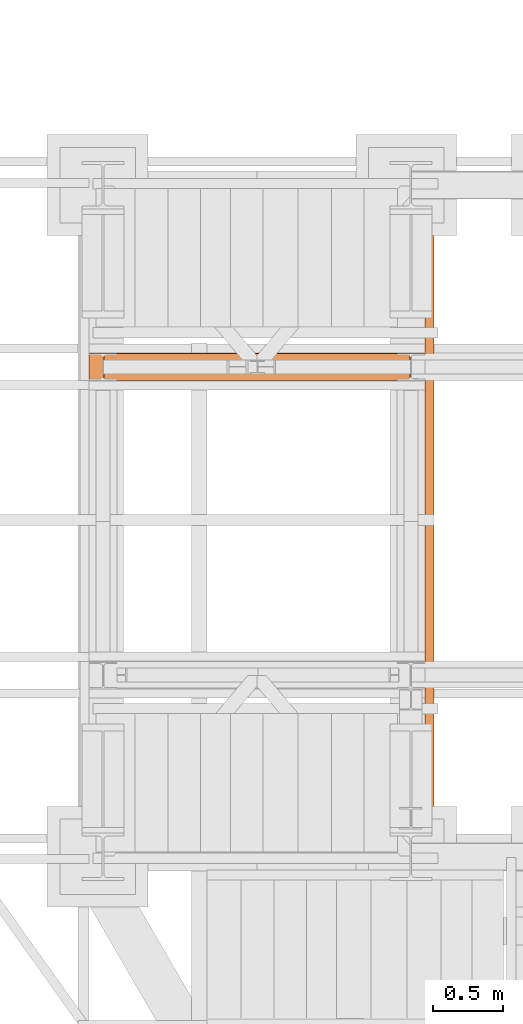
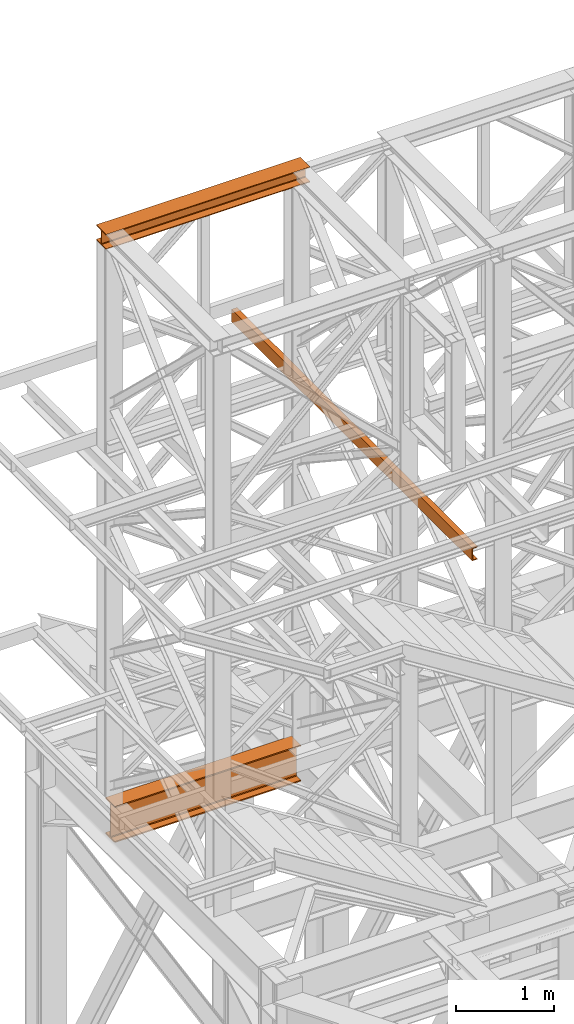
# One storey, part 101 of 208: 3 proxies.
"""IFC2X3 building model written with IfcOpenShell, lengths in millimetres."""

from ifc_helpers import new_model, entity, si_unit, converted_unit, frame, origin, origin_with_axes, place, context, subcontext, project, spatial, faceted_brep, element, save


model = new_model("IFC2X3")

# Units and contexts
model_context = context("Model", 3, precision=1e-05, world=origin())
plan_context = context("Plan", 3, precision=1e-05, world=origin())
body_context = subcontext(model_context, "Body", "Model", "MODEL_VIEW")
ifc_project = project(units=[si_unit("LENGTHUNIT", "METRE", prefix="MILLI"), converted_unit("PLANEANGLEUNIT", "DEGREE", entity("IfcPlaneAngleMeasure", 0.0174532925199433), si_unit("PLANEANGLEUNIT", "RADIAN"), dimensions=[0, 0, 0, 0, 0, 0, 0]), si_unit("AREAUNIT", "SQUARE_METRE"), si_unit("VOLUMEUNIT", "CUBIC_METRE")], contexts=[model_context, plan_context])

# Building, storey
building_placement = place(None, origin())
building = spatial("IfcBuilding", under=ifc_project, at=building_placement, CompositionType="COMPLEX")
storey_placement = place(building_placement, origin_with_axes())
storey = spatial("IfcBuildingStorey", under=building, at=storey_placement, Name="Geschoss", CompositionType="ELEMENT")

# Proxies
proxy_1_placement = place(storey_placement, frame((-3300.745031419179, -13857.57439657637, 4834.989987483023), z_axis=(0.0, 0.0, 1.0), x_axis=(1.0, 0.0, 0.0)))
element("IfcBuildingElementProxy", 1, at=proxy_1_placement, inside=storey, context=body_context, shape_type="Brep", body=[
    faceted_brep([(2188.009999895692, 0.01000000000021828, 450.0100178813937), (2188.009999895692, 190.0100125169756, 450.0100178813937), (2188.009999895692, 190.0100125169756, 435.4100240564349), (2188.009999895692, 120.7100073045494, 435.4100091552737), (2188.009999895692, 109.841562265754, 433.2347078418734), (2188.009999895692, 101.8853126263621, 425.2784563398363), (2188.009999895692, 99.71000619068764, 414.4100113010409), (2188.009999895692, 99.71000619068764, 35.60999167919181), (2188.009999895692, 101.8853126263621, 24.74154664039634), (2188.009999895692, 109.841562265754, 16.78529513835929), (2188.009999895692, 120.7100073045494, 14.60999382495902), (2188.009999895692, 190.0100125169756, 14.60999382495902), (2188.009999895692, 190.0100125169756, 0.01000000000021828), (2188.009999895692, 0.01000000000021828, 0.01000000000021828), (2188.009999895692, 0.01000000000021828, 14.60999382495902), (2188.009999895692, 69.3100052124264, 14.60999382495902), (2188.009999895692, 80.17845025122188, 16.78529513835929), (2188.009999895692, 88.13469989061377, 24.74154664039634), (2188.009999895692, 90.3100063262882, 35.60999167919181), (2188.009999895692, 90.3100063262882, 414.4100113010409), (2188.009999895692, 88.13469989061377, 425.2784563398363), (2188.009999895692, 80.17845025122188, 433.2347078418734), (2188.009999895692, 69.3100052124264, 435.4100091552737), (2188.009999895692, 0.01000000000021828, 435.4100240564349), (2188.009999895692, 190.0100125169756, 450.0100178813937), (2188.009999895692, 0.01000000000021828, 450.0100178813937), (0.01000000000021828, 0.01000000000021828, 450.0100178813937), (0.01000000000021828, 190.0100125169756, 450.0100178813937), (2188.009999895692, 190.0100125169756, 435.4100240564349), (2188.009999895692, 190.0100125169756, 450.0100178813937), (0.01000000000021828, 190.0100125169756, 450.0100178813937), (0.01000000000021828, 190.0100125169756, 435.4100240564349), (2188.009999895692, 120.7100073045494, 435.4100091552737), (2188.009999895692, 190.0100125169756, 435.4100240564349), (0.01000000000021828, 190.0100125169756, 435.4100240564349), (0.01000000000021828, 120.7100073045494, 435.4100091552737), (2188.009999895692, 109.841562265754, 433.2347078418734), (2188.009999895692, 120.7100073045494, 435.4100091552737), (0.01000000000021828, 120.7100073045494, 435.4100091552737), (0.01000000000021828, 109.841562265754, 433.2347078418734), (2188.009999895692, 101.8853126263621, 425.2784563398363), (2188.009999895692, 109.841562265754, 433.2347078418734), (0.01000000000021828, 109.841562265754, 433.2347078418734), (0.01000000000021828, 101.8853126263621, 425.2784563398363), (2188.009999895692, 99.71000619068764, 414.4100113010409), (2188.009999895692, 101.8853126263621, 425.2784563398363), (0.01000000000021828, 101.8853126263621, 425.2784563398363), (0.01000000000021828, 99.71000619068764, 414.4100113010409), (2188.009999895692, 99.71000619068764, 35.60999167919181), (2188.009999895692, 99.71000619068764, 414.4100113010409), (0.01000000000021828, 99.71000619068764, 414.4100113010409), (0.01000000000021828, 99.71000619068764, 35.60999167919181), (2188.009999895692, 101.8853126263621, 24.74154664039634), (2188.009999895692, 99.71000619068764, 35.60999167919181), (0.01000000000021828, 99.71000619068764, 35.60999167919181), (0.01000000000021828, 101.8853126263621, 24.74154664039634), (2188.009999895692, 109.841562265754, 16.78529513835929), (2188.009999895692, 101.8853126263621, 24.74154664039634), (0.01000000000021828, 101.8853126263621, 24.74154664039634), (0.01000000000021828, 109.841562265754, 16.78529513835929), (2188.009999895692, 120.7100073045494, 14.60999382495902), (2188.009999895692, 109.841562265754, 16.78529513835929), (0.01000000000021828, 109.841562265754, 16.78529513835929), (0.01000000000021828, 120.7100073045494, 14.60999382495902), (2188.009999895692, 190.0100125169756, 14.60999382495902), (2188.009999895692, 120.7100073045494, 14.60999382495902), (0.01000000000021828, 120.7100073045494, 14.60999382495902), (0.01000000000021828, 190.0100125169756, 14.60999382495902), (2188.009999895692, 190.0100125169756, 0.01000000000021828), (2188.009999895692, 190.0100125169756, 14.60999382495902), (0.01000000000021828, 190.0100125169756, 14.60999382495902), (0.01000000000021828, 190.0100125169756, 0.01000000000021828), (2188.009999895692, 0.01000000000021828, 0.01000000000021828), (2188.009999895692, 190.0100125169756, 0.01000000000021828), (0.01000000000021828, 190.0100125169756, 0.01000000000021828), (0.01000000000021828, 0.01000000000021828, 0.01000000000021828), (2188.009999895692, 0.01000000000021828, 14.60999382495902), (2188.009999895692, 0.01000000000021828, 0.01000000000021828), (0.01000000000021828, 0.01000000000021828, 0.01000000000021828), (0.01000000000021828, 0.01000000000021828, 14.60999382495902), (2188.009999895692, 69.3100052124264, 14.60999382495902), (2188.009999895692, 0.01000000000021828, 14.60999382495902), (0.01000000000021828, 0.01000000000021828, 14.60999382495902), (0.01000000000021828, 69.3100052124264, 14.60999382495902), (2188.009999895692, 80.17845025122188, 16.78529513835929), (2188.009999895692, 69.3100052124264, 14.60999382495902), (0.01000000000021828, 69.3100052124264, 14.60999382495902), (0.01000000000021828, 80.17845025122188, 16.78529513835929), (2188.009999895692, 88.13469989061377, 24.74154664039634), (2188.009999895692, 80.17845025122188, 16.78529513835929), (0.01000000000021828, 80.17845025122188, 16.78529513835929), (0.01000000000021828, 88.13469989061377, 24.74154664039634), (2188.009999895692, 90.3100063262882, 35.60999167919181), (2188.009999895692, 88.13469989061377, 24.74154664039634), (0.01000000000021828, 88.13469989061377, 24.74154664039634), (0.01000000000021828, 90.3100063262882, 35.60999167919181), (2188.009999895692, 90.3100063262882, 414.4100113010409), (2188.009999895692, 90.3100063262882, 35.60999167919181), (0.01000000000021828, 90.3100063262882, 35.60999167919181), (0.01000000000021828, 90.3100063262882, 414.4100113010409), (2188.009999895692, 88.13469989061377, 425.2784563398363), (2188.009999895692, 90.3100063262882, 414.4100113010409), (0.01000000000021828, 90.3100063262882, 414.4100113010409), (0.01000000000021828, 88.13469989061377, 425.2784563398363), (2188.009999895692, 80.17845025122188, 433.2347078418734), (2188.009999895692, 88.13469989061377, 425.2784563398363), (0.01000000000021828, 88.13469989061377, 425.2784563398363), (0.01000000000021828, 80.17845025122188, 433.2347078418734), (2188.009999895692, 69.3100052124264, 435.4100091552737), (2188.009999895692, 80.17845025122188, 433.2347078418734), (0.01000000000021828, 80.17845025122188, 433.2347078418734), (0.01000000000021828, 69.3100052124264, 435.4100091552737), (2188.009999895692, 0.01000000000021828, 435.4100240564349), (2188.009999895692, 69.3100052124264, 435.4100091552737), (0.01000000000021828, 69.3100052124264, 435.4100091552737), (0.01000000000021828, 0.01000000000021828, 435.4100240564349), (2188.009999895692, 0.01000000000021828, 450.0100178813937), (2188.009999895692, 0.01000000000021828, 435.4100240564349), (0.01000000000021828, 0.01000000000021828, 435.4100240564349), (0.01000000000021828, 0.01000000000021828, 450.0100178813937), (0.01000000000021828, 0.01000000000021828, 450.0100178813937), (0.01000000000021828, 0.01000000000021828, 435.4100240564349), (0.01000000000021828, 69.3100052124264, 435.4100091552737), (0.01000000000021828, 80.17845025122188, 433.2347078418734), (0.01000000000021828, 88.13469989061377, 425.2784563398363), (0.01000000000021828, 90.3100063262882, 414.4100113010409), (0.01000000000021828, 90.3100063262882, 35.60999167919181), (0.01000000000021828, 88.13469989061377, 24.74154664039634), (0.01000000000021828, 80.17845025122188, 16.78529513835929), (0.01000000000021828, 69.3100052124264, 14.60999382495902), (0.01000000000021828, 0.01000000000021828, 14.60999382495902), (0.01000000000021828, 0.01000000000021828, 0.01000000000021828), (0.01000000000021828, 190.0100125169756, 0.01000000000021828), (0.01000000000021828, 190.0100125169756, 14.60999382495902), (0.01000000000021828, 120.7100073045494, 14.60999382495902), (0.01000000000021828, 109.841562265754, 16.78529513835929), (0.01000000000021828, 101.8853126263621, 24.74154664039634), (0.01000000000021828, 99.71000619068764, 35.60999167919181), (0.01000000000021828, 99.71000619068764, 414.4100113010409), (0.01000000000021828, 101.8853126263621, 425.2784563398363), (0.01000000000021828, 109.841562265754, 433.2347078418734), (0.01000000000021828, 120.7100073045494, 435.4100091552737), (0.01000000000021828, 190.0100125169756, 435.4100240564349), (0.01000000000021828, 190.0100125169756, 450.0100178813937)], [[[0, 1, 2, 3, 4, 5, 6, 7, 8, 9, 10, 11, 12, 13, 14, 15, 16, 17, 18, 19, 20, 21, 22, 23]], [[24, 25, 26, 27]], [[28, 29, 30, 31]], [[32, 33, 34, 35]], [[36, 37, 38, 39]], [[40, 41, 42, 43]], [[44, 45, 46, 47]], [[48, 49, 50, 51]], [[52, 53, 54, 55]], [[56, 57, 58, 59]], [[60, 61, 62, 63]], [[64, 65, 66, 67]], [[68, 69, 70, 71]], [[72, 73, 74, 75]], [[76, 77, 78, 79]], [[80, 81, 82, 83]], [[84, 85, 86, 87]], [[88, 89, 90, 91]], [[92, 93, 94, 95]], [[96, 97, 98, 99]], [[100, 101, 102, 103]], [[104, 105, 106, 107]], [[108, 109, 110, 111]], [[112, 113, 114, 115]], [[116, 117, 118, 119]], [[120, 121, 122, 123, 124, 125, 126, 127, 128, 129, 130, 131, 132, 133, 134, 135, 136, 137, 138, 139, 140, 141, 142, 143]]], orient=[[False], [False], [False], [False], [False], [False], [False], [False], [False], [False], [False], [False], [False], [False], [False], [False], [False], [False], [False], [False], [False], [False], [False], [False], [False], [False]]),
])
proxy_2_placement = place(storey_placement, frame((-3406.745032961455, -13862.574391808, 12249.99005869381), z_axis=(0.0, 0.0, 1.0), x_axis=(1.0, 0.0, 0.0)))
element("IfcBuildingElementProxy", 2, at=proxy_2_placement, inside=storey, context=body_context, shape_type="Brep", body=[
    faceted_brep([(0.01000000000021828, 0.01000000000021828, 0.01000000000021828), (0.01000000000021828, 200.0100029802325, 0.01000000000021828), (0.01000000000021828, 200.0100029802325, 10.00999791383765), (0.01000000000021828, 121.2600035762789, 10.01000536441825), (0.01000000000021828, 111.9441915473344, 11.87455041170142), (0.01000000000021828, 105.1245498640838, 18.69419349193595), (0.01000000000021828, 103.2600015571716, 28.01000458955787), (0.01000000000021828, 103.2600015571716, 162.0100153779986), (0.01000000000021828, 105.1245498640838, 171.3258264756205), (0.01000000000021828, 111.9441915473344, 178.145469555855), (0.01000000000021828, 121.2600035762789, 180.0100146031382), (0.01000000000021828, 200.0100029802325, 180.0100146031382), (0.01000000000021828, 200.0100029802325, 190.0100125169756), (0.01000000000021828, 0.01000000000021828, 190.0100125169756), (0.01000000000021828, 0.01000000000021828, 180.0100146031382), (0.01000000000021828, 78.75999940395377, 180.0100146031382), (0.01000000000021828, 88.07581143289826, 178.145469555855), (0.01000000000021828, 94.89545311614893, 171.3258264756205), (0.01000000000021828, 96.76000142306111, 162.0100153779986), (0.01000000000021828, 96.76000142306111, 28.01000458955787), (0.01000000000021828, 94.89545311614893, 18.69419349193595), (0.01000000000021828, 88.07581143289826, 11.87455041170142), (0.01000000000021828, 78.75999940395377, 10.01000536441825), (0.01000000000021828, 0.01000000000021828, 10.00999791383765), (0.01000000000021828, 200.0100029802325, 0.01000000000021828), (0.01000000000021828, 0.01000000000021828, 0.01000000000021828), (2400.010002980234, 0.01000000000021828, 0.01000000000021828), (2400.010002980234, 200.0100029802325, 0.01000000000021828), (0.01000000000021828, 200.0100029802325, 10.00999791383765), (0.01000000000021828, 200.0100029802325, 0.01000000000021828), (2400.010002980234, 200.0100029802325, 0.01000000000021828), (2400.010002980234, 200.0100029802325, 10.00999791383765), (0.01000000000021828, 121.2600035762789, 10.01000536441825), (0.01000000000021828, 200.0100029802325, 10.00999791383765), (2400.010002980234, 200.0100029802325, 10.00999791383765), (2400.010002980234, 121.2600035762789, 10.01000536441825), (0.01000000000021828, 111.9441915473344, 11.87455041170142), (0.01000000000021828, 121.2600035762789, 10.01000536441825), (2400.010002980234, 121.2600035762789, 10.01000536441825), (2400.010002980234, 111.9441915473344, 11.87455041170142), (0.01000000000021828, 105.1245498640838, 18.69419349193595), (0.01000000000021828, 111.9441915473344, 11.87455041170142), (2400.010002980234, 111.9441915473344, 11.87455041170142), (2400.010002980234, 105.1245498640838, 18.69419349193595), (0.01000000000021828, 103.2600015571716, 28.01000458955787), (0.01000000000021828, 105.1245498640838, 18.69419349193595), (2400.010002980234, 105.1245498640838, 18.69419349193595), (2400.010002980234, 103.2600015571716, 28.01000458955787), (0.01000000000021828, 103.2600015571716, 162.0100153779986), (0.01000000000021828, 103.2600015571716, 28.01000458955787), (2400.010002980234, 103.2600015571716, 28.01000458955787), (2400.010002980234, 103.2600015571716, 162.0100153779986), (0.01000000000021828, 105.1245498640838, 171.3258264756205), (0.01000000000021828, 103.2600015571716, 162.0100153779986), (2400.010002980234, 103.2600015571716, 162.0100153779986), (2400.010002980234, 105.1245498640838, 171.3258264756205), (0.01000000000021828, 111.9441915473344, 178.145469555855), (0.01000000000021828, 105.1245498640838, 171.3258264756205), (2400.010002980234, 105.1245498640838, 171.3258264756205), (2400.010002980234, 111.9441915473344, 178.145469555855), (0.01000000000021828, 121.2600035762789, 180.0100146031382), (0.01000000000021828, 111.9441915473344, 178.145469555855), (2400.010002980234, 111.9441915473344, 178.145469555855), (2400.010002980234, 121.2600035762789, 180.0100146031382), (0.01000000000021828, 200.0100029802325, 180.0100146031382), (0.01000000000021828, 121.2600035762789, 180.0100146031382), (2400.010002980234, 121.2600035762789, 180.0100146031382), (2400.010002980234, 200.0100029802325, 180.0100146031382), (0.01000000000021828, 200.0100029802325, 190.0100125169756), (0.01000000000021828, 200.0100029802325, 180.0100146031382), (2400.010002980234, 200.0100029802325, 180.0100146031382), (2400.010002980234, 200.0100029802325, 190.0100125169756), (0.01000000000021828, 0.01000000000021828, 190.0100125169756), (0.01000000000021828, 200.0100029802325, 190.0100125169756), (2400.010002980234, 200.0100029802325, 190.0100125169756), (2400.010002980234, 0.01000000000021828, 190.0100125169756), (0.01000000000021828, 0.01000000000021828, 180.0100146031382), (0.01000000000021828, 0.01000000000021828, 190.0100125169756), (2400.010002980234, 0.01000000000021828, 190.0100125169756), (2400.010002980234, 0.01000000000021828, 180.0100146031382), (0.01000000000021828, 78.75999940395377, 180.0100146031382), (0.01000000000021828, 0.01000000000021828, 180.0100146031382), (2400.010002980234, 0.01000000000021828, 180.0100146031382), (2400.010002980234, 78.75999940395377, 180.0100146031382), (0.01000000000021828, 88.07581143289826, 178.145469555855), (0.01000000000021828, 78.75999940395377, 180.0100146031382), (2400.010002980234, 78.75999940395377, 180.0100146031382), (2400.010002980234, 88.07581143289826, 178.145469555855), (0.01000000000021828, 94.89545311614893, 171.3258264756205), (0.01000000000021828, 88.07581143289826, 178.145469555855), (2400.010002980234, 88.07581143289826, 178.145469555855), (2400.010002980234, 94.89545311614893, 171.3258264756205), (0.01000000000021828, 96.76000142306111, 162.0100153779986), (0.01000000000021828, 94.89545311614893, 171.3258264756205), (2400.010002980234, 94.89545311614893, 171.3258264756205), (2400.010002980234, 96.76000142306111, 162.0100153779986), (0.01000000000021828, 96.76000142306111, 28.01000458955787), (0.01000000000021828, 96.76000142306111, 162.0100153779986), (2400.010002980234, 96.76000142306111, 162.0100153779986), (2400.010002980234, 96.76000142306111, 28.01000458955787), (0.01000000000021828, 94.89545311614893, 18.69419349193595), (0.01000000000021828, 96.76000142306111, 28.01000458955787), (2400.010002980234, 96.76000142306111, 28.01000458955787), (2400.010002980234, 94.89545311614893, 18.69419349193595), (0.01000000000021828, 88.07581143289826, 11.87455041170142), (0.01000000000021828, 94.89545311614893, 18.69419349193595), (2400.010002980234, 94.89545311614893, 18.69419349193595), (2400.010002980234, 88.07581143289826, 11.87455041170142), (0.01000000000021828, 78.75999940395377, 10.01000536441825), (0.01000000000021828, 88.07581143289826, 11.87455041170142), (2400.010002980234, 88.07581143289826, 11.87455041170142), (2400.010002980234, 78.75999940395377, 10.01000536441825), (0.01000000000021828, 0.01000000000021828, 10.00999791383765), (0.01000000000021828, 78.75999940395377, 10.01000536441825), (2400.010002980234, 78.75999940395377, 10.01000536441825), (2400.010002980234, 0.01000000000021828, 10.00999791383765), (0.01000000000021828, 0.01000000000021828, 0.01000000000021828), (0.01000000000021828, 0.01000000000021828, 10.00999791383765), (2400.010002980234, 0.01000000000021828, 10.00999791383765), (2400.010002980234, 0.01000000000021828, 0.01000000000021828), (2400.010002980234, 0.01000000000021828, 0.01000000000021828), (2400.010002980234, 0.01000000000021828, 10.00999791383765), (2400.010002980234, 78.75999940395377, 10.01000536441825), (2400.010002980234, 88.07581143289826, 11.87455041170142), (2400.010002980234, 94.89545311614893, 18.69419349193595), (2400.010002980234, 96.76000142306111, 28.01000458955787), (2400.010002980234, 96.76000142306111, 162.0100153779986), (2400.010002980234, 94.89545311614893, 171.3258264756205), (2400.010002980234, 88.07581143289826, 178.145469555855), (2400.010002980234, 78.75999940395377, 180.0100146031382), (2400.010002980234, 0.01000000000021828, 180.0100146031382), (2400.010002980234, 0.01000000000021828, 190.0100125169756), (2400.010002980234, 200.0100029802325, 190.0100125169756), (2400.010002980234, 200.0100029802325, 180.0100146031382), (2400.010002980234, 121.2600035762789, 180.0100146031382), (2400.010002980234, 111.9441915473344, 178.145469555855), (2400.010002980234, 105.1245498640838, 171.3258264756205), (2400.010002980234, 103.2600015571716, 162.0100153779986), (2400.010002980234, 103.2600015571716, 28.01000458955787), (2400.010002980234, 105.1245498640838, 18.69419349193595), (2400.010002980234, 111.9441915473344, 11.87455041170142), (2400.010002980234, 121.2600035762789, 10.01000536441825), (2400.010002980234, 200.0100029802325, 10.00999791383765), (2400.010002980234, 200.0100029802325, 0.01000000000021828)], [[[0, 1, 2, 3, 4, 5, 6, 7, 8, 9, 10, 11, 12, 13, 14, 15, 16, 17, 18, 19, 20, 21, 22, 23]], [[24, 25, 26, 27]], [[28, 29, 30, 31]], [[32, 33, 34, 35]], [[36, 37, 38, 39]], [[40, 41, 42, 43]], [[44, 45, 46, 47]], [[48, 49, 50, 51]], [[52, 53, 54, 55]], [[56, 57, 58, 59]], [[60, 61, 62, 63]], [[64, 65, 66, 67]], [[68, 69, 70, 71]], [[72, 73, 74, 75]], [[76, 77, 78, 79]], [[80, 81, 82, 83]], [[84, 85, 86, 87]], [[88, 89, 90, 91]], [[92, 93, 94, 95]], [[96, 97, 98, 99]], [[100, 101, 102, 103]], [[104, 105, 106, 107]], [[108, 109, 110, 111]], [[112, 113, 114, 115]], [[116, 117, 118, 119]], [[120, 121, 122, 123, 124, 125, 126, 127, 128, 129, 130, 131, 132, 133, 134, 135, 136, 137, 138, 139, 140, 141, 142, 143]]], orient=[[False], [False], [False], [False], [False], [False], [False], [False], [False], [False], [False], [False], [False], [False], [False], [False], [False], [False], [False], [False], [False], [False], [False], [False], [False], [False]]),
])
proxy_3_placement = place(storey_placement, frame((-1006.745029981221, -17162.574391808, 9539.989999999998), z_axis=(0.0, 0.0, 1.0), x_axis=(1.0, 0.0, 0.0)))
element("IfcBuildingElementProxy", 3, at=proxy_3_placement, inside=storey, context=body_context, shape_type="Brep", body=[
    faceted_brep([(65.00999999999999, 4899.878890000196, 0.01000000000021828), (65.00999999999999, 0.00999999999839929, 0.01000000000021828), (65.00999999999999, 0.00999999999839929, 3.132428070246533), (65.00999999999999, 4899.878890000196, 3.132428070246533), (65.00999999999999, 4899.878890000196, 3.132428070246533), (65.00999999999999, 0.00999999999839929, 3.132428070246533), (64.76726342282541, 0.00999999999839929, 4.748288908171162), (64.76726342282541, 4899.878890000196, 4.748288908171162), (64.76726342282541, 4899.878890000196, 4.748288908171162), (64.76726342282541, 0.00999999999839929, 4.748288908171162), (64.06053228585529, 0.00999999999839929, 6.221534443444398), (64.06053228585529, 4899.878890000196, 6.221534443444398), (64.06053228585529, 4899.878890000196, 6.221534443444398), (64.06053228585529, 0.00999999999839929, 6.221534443444398), (62.9521516384682, 0.00999999999839929, 7.422126703873801), (62.9521516384682, 4899.878890000196, 7.422126703873801), (62.9521516384682, 4899.878890000196, 7.422126703873801), (62.9521516384682, 0.00999999999839929, 7.422126703873801), (61.53995641148299, 0.00999999999839929, 8.244091391710754), (61.53995641148299, 4899.878890000196, 8.244091391710754), (61.53995641148299, 4899.878890000196, 8.244091391710754), (61.53995641148299, 0.00999999999839929, 8.244091391710754), (59.94859872255415, 0.00999999999839929, 8.614912102195376), (59.94859872255415, 4899.878890000196, 8.614912102195376), (59.94859872255415, 4899.878890000196, 8.614912102195376), (59.94859872255415, 0.00999999999839929, 8.614912102195376), (17.17267516602965, 0.00999999999839929, 12.0369859867169), (17.17267516602965, 4899.878890000196, 12.0369859867169), (17.17267516602965, 4899.878890000196, 12.0369859867169), (17.17267516602965, 0.00999999999839929, 12.0369859867169), (14.13462866898203, 0.00999999999839929, 12.74491643400506), (14.13462866898203, 4899.878890000196, 12.74491643400506), (14.13462866898203, 4899.878890000196, 12.74491643400506), (14.13462866898203, 0.00999999999839929, 12.74491643400506), (11.43861959928631, 0.00999999999839929, 14.31412174714933), (11.43861959928631, 4899.878890000196, 14.31412174714933), (11.43861959928631, 4899.878890000196, 14.31412174714933), (11.43861959928631, 0.00999999999839929, 14.31412174714933), (9.322620181546654, 0.00999999999839929, 16.60616151705835), (9.322620181546654, 4899.878890000196, 16.60616151705835), (9.322620181546654, 4899.878890000196, 16.60616151705835), (9.322620181546654, 0.00999999999839929, 16.60616151705835), (7.973406192784523, 0.00999999999839929, 19.41872117530875), (7.973406192784523, 4899.878890000196, 19.41872117530875), (7.973406192784523, 4899.878890000196, 19.41872117530875), (7.973406192784523, 0.00999999999839929, 19.41872117530875), (7.509999999999991, 0.00999999999839929, 22.50354641134618), (7.509999999999991, 4899.878890000196, 22.50354641134618), (7.509999999999991, 4899.878890000196, 22.50354641134618), (7.509999999999991, 0.00999999999839929, 22.50354641134618), (7.509999999999991, 0.00999999999839929, 137.5164535886524), (7.509999999999991, 4899.878890000196, 137.5164535886524), (7.509999999999991, 4899.878890000196, 137.5164535886524), (7.509999999999991, 0.00999999999839929, 137.5164535886524), (7.973406192784523, 0.00999999999839929, 140.6012788246917), (7.973406192784523, 4899.878890000196, 140.6012788246917), (7.973406192784523, 4899.878890000196, 140.6012788246917), (7.973406192784523, 0.00999999999839929, 140.6012788246917), (9.322620181546654, 0.00999999999839929, 143.4138384829403), (9.322620181546654, 4899.878890000196, 143.4138384829403), (9.322620181546654, 4899.878890000196, 143.4138384829403), (9.322620181546654, 0.00999999999839929, 143.4138384829403), (11.43861959928631, 0.00999999999839929, 145.7058782528493), (11.43861959928631, 4899.878890000196, 145.7058782528493), (11.43861959928631, 4899.878890000196, 145.7058782528493), (11.43861959928631, 0.00999999999839929, 145.7058782528493), (14.13462866898203, 0.00999999999839929, 147.2750835659936), (14.13462866898203, 4899.878890000196, 147.2750835659936), (14.13462866898203, 4899.878890000196, 147.2750835659936), (14.13462866898203, 0.00999999999839929, 147.2750835659936), (17.17267516602965, 0.00999999999839929, 147.9830140132817), (17.17267516602965, 4899.878890000196, 147.9830140132817), (17.17267516602965, 4899.878890000196, 147.9830140132817), (17.17267516602965, 0.00999999999839929, 147.9830140132817), (59.94859872255415, 0.00999999999839929, 151.4050878978032), (59.94859872255415, 4899.878890000196, 151.4050878978032), (59.94859872255415, 4899.878890000196, 151.4050878978032), (59.94859872255415, 0.00999999999839929, 151.4050878978032), (61.53995641148299, 0.00999999999839929, 151.7759086082879), (61.53995641148299, 4899.878890000196, 151.7759086082879), (61.53995641148299, 4899.878890000196, 151.7759086082879), (61.53995641148299, 0.00999999999839929, 151.7759086082879), (62.9521516384682, 0.00999999999839929, 152.5978732961248), (62.9521516384682, 4899.878890000196, 152.5978732961248), (62.9521516384682, 4899.878890000196, 152.5978732961248), (62.9521516384682, 0.00999999999839929, 152.5978732961248), (64.06053228585529, 0.00999999999839929, 153.7984655565542), (64.06053228585529, 4899.878890000196, 153.7984655565542), (64.06053228585529, 4899.878890000196, 153.7984655565542), (64.06053228585529, 0.00999999999839929, 153.7984655565542), (64.76726342282541, 0.00999999999839929, 155.2717110918275), (64.76726342282541, 4899.878890000196, 155.2717110918275), (64.76726342282541, 4899.878890000196, 155.2717110918275), (64.76726342282541, 0.00999999999839929, 155.2717110918275), (65.00999999999999, 0.00999999999839929, 156.8875719297521), (65.00999999999999, 4899.878890000196, 156.8875719297521), (65.00999999999999, 4899.878890000196, 156.8875719297521), (65.00999999999999, 0.00999999999839929, 156.8875719297521), (65.00999999999999, 0.00999999999839929, 160.0100000000002), (65.00999999999999, 4899.878890000196, 160.0100000000002), (65.00999999999999, 4899.878890000196, 160.0100000000002), (65.00999999999999, 0.00999999999839929, 160.0100000000002), (0.009999999999990905, 0.00999999999839929, 160.0100000000002), (0.009999999999990905, 4899.878890000196, 160.0100000000002), (0.009999999999990905, 4899.878890000196, 160.0100000000002), (0.009999999999990905, 0.00999999999839929, 160.0100000000002), (0.009999999999990905, 0.00999999999839929, 0.01000000000021828), (0.009999999999990905, 4899.878890000196, 0.01000000000021828), (0.009999999999990905, 4899.878890000196, 0.01000000000021828), (0.009999999999990905, 0.00999999999839929, 0.01000000000021828), (65.00999999999999, 0.00999999999839929, 0.01000000000021828), (65.00999999999999, 4899.878890000196, 0.01000000000021828), (65.00999999999999, 4899.878890000196, 0.01000000000021828), (65.00999999999999, 4899.878890000196, 3.132428070246533), (64.76726342282541, 4899.878890000196, 4.748288908171162), (64.06053228585529, 4899.878890000196, 6.221534443444398), (62.9521516384682, 4899.878890000196, 7.422126703873801), (61.53995641148299, 4899.878890000196, 8.244091391710754), (59.94859872255415, 4899.878890000196, 8.614912102195376), (17.17267516602965, 4899.878890000196, 12.0369859867169), (14.13462866898203, 4899.878890000196, 12.74491643400506), (11.43861959928631, 4899.878890000196, 14.31412174714933), (9.322620181546654, 4899.878890000196, 16.60616151705835), (7.973406192784523, 4899.878890000196, 19.41872117530875), (7.509999999999991, 4899.878890000196, 22.50354641134618), (7.509999999999991, 4899.878890000196, 137.5164535886524), (7.973406192784523, 4899.878890000196, 140.6012788246917), (9.322620181546654, 4899.878890000196, 143.4138384829403), (11.43861959928631, 4899.878890000196, 145.7058782528493), (14.13462866898203, 4899.878890000196, 147.2750835659936), (17.17267516602965, 4899.878890000196, 147.9830140132817), (59.94859872255415, 4899.878890000196, 151.4050878978032), (61.53995641148299, 4899.878890000196, 151.7759086082879), (62.9521516384682, 4899.878890000196, 152.5978732961248), (64.06053228585529, 4899.878890000196, 153.7984655565542), (64.76726342282541, 4899.878890000196, 155.2717110918275), (65.00999999999999, 4899.878890000196, 156.8875719297521), (65.00999999999999, 4899.878890000196, 160.0100000000002), (0.009999999999990905, 4899.878890000196, 160.0100000000002), (0.009999999999990905, 4899.878890000196, 0.01000000000021828), (65.00999999999999, 0.00999999999839929, 0.01000000000021828), (0.009999999999990905, 0.00999999999839929, 0.01000000000021828), (0.009999999999990905, 0.00999999999839929, 160.0100000000002), (65.00999999999999, 0.00999999999839929, 160.0100000000002), (65.00999999999999, 0.00999999999839929, 156.8875719297521), (64.76726342282541, 0.00999999999839929, 155.2717110918275), (64.06053228585529, 0.00999999999839929, 153.7984655565542), (62.9521516384682, 0.00999999999839929, 152.5978732961248), (61.53995641148299, 0.00999999999839929, 151.7759086082879), (59.94859872255415, 0.00999999999839929, 151.4050878978032), (17.17267516602965, 0.00999999999839929, 147.9830140132817), (14.13462866898203, 0.00999999999839929, 147.2750835659936), (11.43861959928631, 0.00999999999839929, 145.7058782528493), (9.322620181546654, 0.00999999999839929, 143.4138384829403), (7.973406192784523, 0.00999999999839929, 140.6012788246917), (7.509999999999991, 0.00999999999839929, 137.5164535886524), (7.509999999999991, 0.00999999999839929, 22.50354641134618), (7.973406192784523, 0.00999999999839929, 19.41872117530875), (9.322620181546654, 0.00999999999839929, 16.60616151705835), (11.43861959928631, 0.00999999999839929, 14.31412174714933), (14.13462866898203, 0.00999999999839929, 12.74491643400506), (17.17267516602965, 0.00999999999839929, 12.0369859867169), (59.94859872255415, 0.00999999999839929, 8.614912102195376), (61.53995641148299, 0.00999999999839929, 8.244091391710754), (62.9521516384682, 0.00999999999839929, 7.422126703873801), (64.06053228585529, 0.00999999999839929, 6.221534443444398), (64.76726342282541, 0.00999999999839929, 4.748288908171162), (65.00999999999999, 0.00999999999839929, 3.132428070246533)], [[[0, 1, 2, 3]], [[4, 5, 6, 7]], [[8, 9, 10, 11]], [[12, 13, 14, 15]], [[16, 17, 18, 19]], [[20, 21, 22, 23]], [[24, 25, 26, 27]], [[28, 29, 30, 31]], [[32, 33, 34, 35]], [[36, 37, 38, 39]], [[40, 41, 42, 43]], [[44, 45, 46, 47]], [[48, 49, 50, 51]], [[52, 53, 54, 55]], [[56, 57, 58, 59]], [[60, 61, 62, 63]], [[64, 65, 66, 67]], [[68, 69, 70, 71]], [[72, 73, 74, 75]], [[76, 77, 78, 79]], [[80, 81, 82, 83]], [[84, 85, 86, 87]], [[88, 89, 90, 91]], [[92, 93, 94, 95]], [[96, 97, 98, 99]], [[100, 101, 102, 103]], [[104, 105, 106, 107]], [[108, 109, 110, 111]], [[112, 113, 114, 115, 116, 117, 118, 119, 120, 121, 122, 123, 124, 125, 126, 127, 128, 129, 130, 131, 132, 133, 134, 135, 136, 137, 138, 139]], [[140, 141, 142, 143, 144, 145, 146, 147, 148, 149, 150, 151, 152, 153, 154, 155, 156, 157, 158, 159, 160, 161, 162, 163, 164, 165, 166, 167]]], orient=[[False], [False], [False], [False], [False], [False], [False], [False], [False], [False], [False], [False], [False], [False], [False], [False], [False], [False], [False], [False], [False], [False], [False], [False], [False], [False], [False], [False], [False], [False]]),
])

save(model, "model.ifc")
